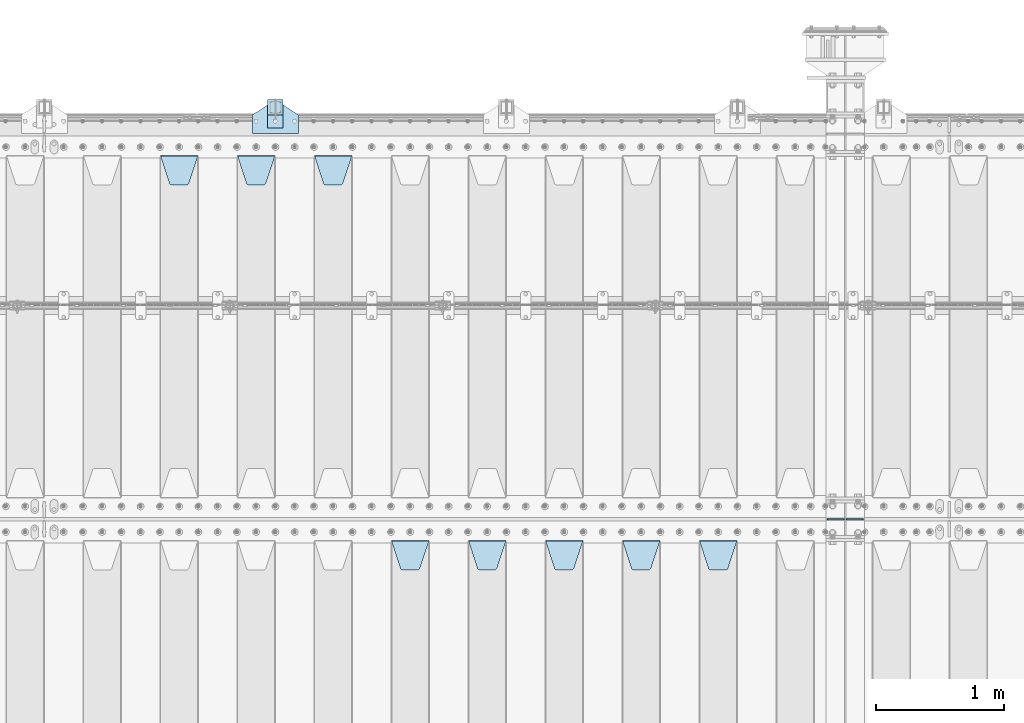
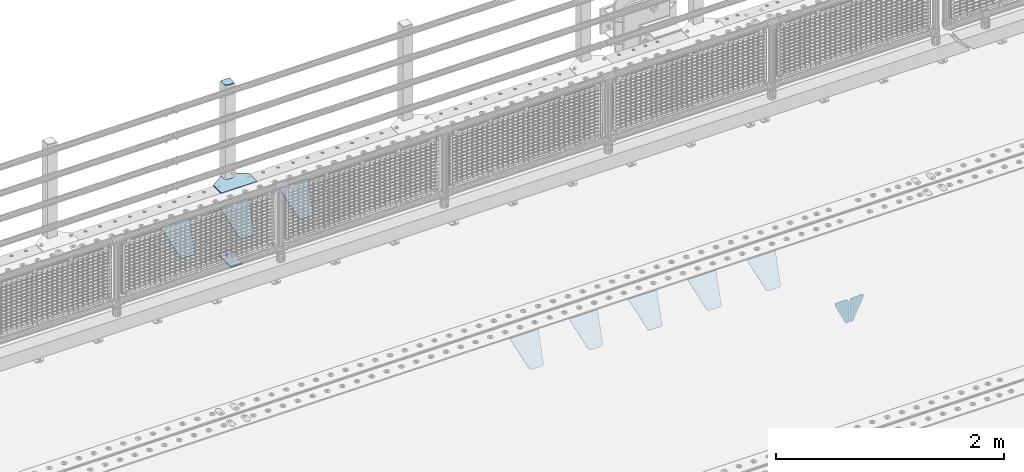
# One storey, part 216 of 240: 14 plates.
"""IFC2X3 building model written with IfcOpenShell, lengths in millimetres."""

from ifc_helpers import new_model, si_unit, frame, origin_with_axes, place, context, subcontext, project, spatial, faceted_brep, material, type_object, element, save


model = new_model("IFC2X3")

# Units and contexts
model_context = context("Model", 3, precision=1e-05, world=origin_with_axes())
body_context = subcontext(model_context, "Body", "Model", "MODEL_VIEW")
ifc_project = project(units=[si_unit("LENGTHUNIT", "METRE", prefix="MILLI"), si_unit("AREAUNIT", "SQUARE_METRE"), si_unit("VOLUMEUNIT", "CUBIC_METRE"), si_unit("MASSUNIT", "GRAM", prefix="KILO"), si_unit("TIMEUNIT", "SECOND"), si_unit("PLANEANGLEUNIT", "RADIAN"), si_unit("SOLIDANGLEUNIT", "STERADIAN"), si_unit("THERMODYNAMICTEMPERATUREUNIT", "DEGREE_CELSIUS"), si_unit("LUMINOUSINTENSITYUNIT", "LUMEN")], contexts=[model_context])

# Site, building, storey
site_placement = place(None, origin_with_axes())
site = spatial("IfcSite", under=ifc_project, at=site_placement, CompositionType="ELEMENT")
building_placement = place(site_placement, origin_with_axes())
building = spatial("IfcBuilding", under=site, at=building_placement, Name="Standard", CompositionType="ELEMENT")
storey_placement = place(building_placement, origin_with_axes())
storey = spatial("IfcBuildingStorey", under=building, at=storey_placement, Name="Undefined", CompositionType="ELEMENT", Elevation=0.0)

# Plates
ifc_material_1 = material(Name="STEEL/S355N")
plate_type_1 = type_object("IfcPlateType", PredefinedType="NOTDEFINED")
for number, where, z_axis, x_axis in (
    (1, (52833.499999997, 33000.0000000345, -915.000018222273), (0.0, 0.0, -1.0), (-1.0, 0.0, 0.0)),
    (2, (52846.4999999972, 33000.0000000345, -915.000018222272), (0.0, 0.0, -1.0), (1.0, 0.0, 0.0)),
):
    element("IfcPlate", number, at=place(storey_placement, frame(where, z_axis=z_axis, x_axis=x_axis)), inside=storey, type_object=plate_type_1, material=ifc_material_1, context=body_context, shape_type="Brep", body=[
        faceted_brep([(0.0, -5.0, 27.0), (0.0, -5.0, 250.0), (0.0, 5.0, 250.0), (0.0, 5.0, 27.0), (30.0, -5.0, 250.0), (30.0, 5.0, 250.0), (135.0, -5.0, 30.0), (135.0, 5.0, 30.0), (135.0, -5.0, 0.0), (135.0, 5.0, 0.0), (27.0, -5.0, 0.0), (27.0, 5.0, 0.0), (22.311499202995, -5.0, 0.410190668670339), (22.311499202995, 5.0, 0.410190668670339), (17.7654561302043, -5.0, 1.62829923878053), (17.7654561302043, 5.0, 1.62829923878053), (13.5, -5.0, 3.6173140978201), (13.5, 5.0, 3.6173140978201), (9.64473453846585, -5.0, 6.31680003578754), (9.64473453846585, 5.0, 6.31680003578754), (6.31680003579095, -5.0, 9.64473453846347), (6.31680003579095, 5.0, 9.64473453846347), (3.61731409782078, -5.0, 13.5), (3.61731409782078, 5.0, 13.5), (1.62829923877871, -5.0, 17.765456130207), (1.62829923877871, 5.0, 17.765456130207), (0.410190668670111, -5.0, 22.3114992029929), (0.410190668670111, 5.0, 22.3114992029929)], [[[0, 1, 2, 3]], [[1, 4, 5, 2]], [[4, 6, 7, 5]], [[6, 8, 9, 7]], [[8, 10, 11, 9]], [[10, 12, 13, 11]], [[12, 14, 15, 13]], [[14, 16, 17, 15]], [[16, 18, 19, 17]], [[18, 20, 21, 19]], [[20, 22, 23, 21]], [[22, 24, 25, 23]], [[24, 26, 27, 25]], [[26, 0, 3, 27]], [[5, 7, 9, 11, 13, 15, 17, 19, 21, 23, 25, 27, 3, 2]], [[26, 24, 22, 20, 18, 16, 14, 12, 10, 8, 6, 4, 1, 0]]]),
    ])
plate_type_2 = type_object("IfcPlateType", PredefinedType="NOTDEFINED")
plate_1_placement = place(storey_placement, frame((51705.0, 32831.767766956, -1.76776695296758), z_axis=(0.0, -0.707106781186547, -0.707106781186548), x_axis=(1.0, 0.0, 0.0)))
element("IfcPlate", 3, at=plate_1_placement, inside=storey, type_object=plate_type_2, material=ifc_material_1, context=body_context, shape_type="Brep", body=[
    faceted_brep([(0.0, -2.5, 0.0), (69.345504679477, -2.50000000000364, 300.171731424827), (69.345504679477, 2.49999999999636, 300.171731424827), (0.0, 2.5, 0.0), (70.927406119954, -2.50000000000364, 304.897442415397), (70.927406119954, 2.49999999999636, 304.897442415397), (73.3818627772271, -2.50000000000728, 309.234538108525), (73.3818627772271, 2.49999999999636, 309.234538108529), (76.6187032999587, -2.50000000000728, 313.023683126099), (76.6187032999587, 2.49999999999636, 313.023683126103), (80.5190132705029, -2.50000000000364, 316.125672595368), (80.5190132705029, 2.49999999999636, 316.125672595368), (84.9395038596849, -2.50000000000364, 318.426546230472), (84.9395038596849, 2.49999999999636, 318.426546230472), (89.7177759439219, -2.5, 319.841774983277), (89.7177759439219, 2.49999999999636, 319.841774983273), (94.6782862926484, -2.50000000000364, 320.319366455074), (94.6782862926484, 2.49999999999636, 320.319366455074), (195.321713707352, -2.50000000000364, 320.319366455074), (195.321713707352, 2.49999999999636, 320.319366455074), (200.282224056078, -2.50000000000364, 319.841774983273), (200.282224056078, 2.49999999999636, 319.841774983273), (205.060496140315, -2.50000000000364, 318.426546230472), (205.060496140315, 2.49999999999636, 318.426546230472), (209.480986729497, -2.50000000000364, 316.125672595368), (209.480986729497, 2.49999999999636, 316.125672595368), (213.381296700041, -2.50000000000728, 313.023683126099), (213.381296700041, 2.49999999999272, 313.023683126099), (216.618137222766, -2.50000000000364, 309.234538108522), (216.618137222766, 2.49999999999636, 309.234538108522), (219.072593880039, -2.50000000000364, 304.897442415397), (219.072593880039, 2.49999999999636, 304.897442415397), (220.654495320523, -2.50000000000364, 300.171731424827), (220.654495320523, 2.49999999999636, 300.171731424827), (290.0, -2.50000000000364, -3.63797880709171e-12), (290.0, 2.49999999999636, -3.63797880709171e-12)], [[[0, 1, 2, 3]], [[1, 4, 5, 2]], [[4, 6, 7, 5]], [[6, 8, 9, 7]], [[8, 10, 11, 9]], [[10, 12, 13, 11]], [[12, 14, 15, 13]], [[14, 16, 17, 15]], [[16, 18, 19, 17]], [[18, 20, 21, 19]], [[20, 22, 23, 21]], [[22, 24, 25, 23]], [[24, 26, 27, 25]], [[26, 28, 29, 27]], [[28, 30, 31, 29]], [[30, 32, 33, 31]], [[32, 34, 35, 33]], [[34, 0, 3, 35]], [[5, 7, 9, 11, 13, 15, 17, 19, 21, 23, 25, 27, 29, 31, 33, 35, 3, 2]], [[34, 32, 30, 28, 26, 24, 22, 20, 18, 16, 14, 12, 10, 8, 6, 4, 1, 0]]]),
])
plate_2_placement = place(storey_placement, frame((51105.0, 32831.767766956, -1.76776695296758), z_axis=(0.0, -0.707106781186547, -0.707106781186548), x_axis=(1.0, 0.0, 0.0)))
element("IfcPlate", 4, at=plate_2_placement, inside=storey, type_object=plate_type_2, material=ifc_material_1, context=body_context, shape_type="Brep", body=[
    faceted_brep([(0.0, -2.5, 0.0), (69.345504679477, -2.50000000000364, 300.171731424827), (69.345504679477, 2.49999999999636, 300.171731424827), (0.0, 2.5, 0.0), (70.927406119954, -2.50000000000364, 304.897442415397), (70.927406119954, 2.49999999999636, 304.897442415397), (73.3818627772271, -2.50000000000728, 309.234538108525), (73.3818627772271, 2.49999999999636, 309.234538108529), (76.6187032999587, -2.50000000000728, 313.023683126099), (76.6187032999587, 2.49999999999636, 313.023683126103), (80.5190132705029, -2.50000000000364, 316.125672595368), (80.5190132705029, 2.49999999999636, 316.125672595368), (84.9395038596849, -2.50000000000364, 318.426546230472), (84.9395038596849, 2.49999999999636, 318.426546230472), (89.7177759439219, -2.5, 319.841774983277), (89.7177759439219, 2.49999999999636, 319.841774983273), (94.6782862926484, -2.50000000000364, 320.319366455074), (94.6782862926484, 2.49999999999636, 320.319366455074), (195.321713707352, -2.50000000000364, 320.319366455074), (195.321713707352, 2.49999999999636, 320.319366455074), (200.282224056078, -2.50000000000364, 319.841774983273), (200.282224056078, 2.49999999999636, 319.841774983273), (205.060496140315, -2.50000000000364, 318.426546230472), (205.060496140315, 2.49999999999636, 318.426546230472), (209.480986729497, -2.50000000000364, 316.125672595368), (209.480986729497, 2.49999999999636, 316.125672595368), (213.381296700041, -2.50000000000728, 313.023683126099), (213.381296700041, 2.49999999999272, 313.023683126099), (216.618137222766, -2.50000000000364, 309.234538108522), (216.618137222766, 2.49999999999636, 309.234538108522), (219.072593880039, -2.50000000000364, 304.897442415397), (219.072593880039, 2.49999999999636, 304.897442415397), (220.654495320523, -2.50000000000364, 300.171731424827), (220.654495320523, 2.49999999999636, 300.171731424827), (290.0, -2.50000000000364, -3.63797880709171e-12), (290.0, 2.49999999999636, -3.63797880709171e-12)], [[[0, 1, 2, 3]], [[1, 4, 5, 2]], [[4, 6, 7, 5]], [[6, 8, 9, 7]], [[8, 10, 11, 9]], [[10, 12, 13, 11]], [[12, 14, 15, 13]], [[14, 16, 17, 15]], [[16, 18, 19, 17]], [[18, 20, 21, 19]], [[20, 22, 23, 21]], [[22, 24, 25, 23]], [[24, 26, 27, 25]], [[26, 28, 29, 27]], [[28, 30, 31, 29]], [[30, 32, 33, 31]], [[32, 34, 35, 33]], [[34, 0, 3, 35]], [[5, 7, 9, 11, 13, 15, 17, 19, 21, 23, 25, 27, 29, 31, 33, 35, 3, 2]], [[34, 32, 30, 28, 26, 24, 22, 20, 18, 16, 14, 12, 10, 8, 6, 4, 1, 0]]]),
])
plate_3_placement = place(storey_placement, frame((50505.0, 32831.767766956, -1.76776695296758), z_axis=(0.0, -0.707106781186547, -0.707106781186548), x_axis=(1.0, 0.0, 0.0)))
element("IfcPlate", 5, at=plate_3_placement, inside=storey, type_object=plate_type_2, material=ifc_material_1, context=body_context, shape_type="Brep", body=[
    faceted_brep([(0.0, -2.5, 0.0), (69.345504679477, -2.50000000000364, 300.171731424827), (69.345504679477, 2.49999999999636, 300.171731424827), (0.0, 2.5, 0.0), (70.927406119954, -2.50000000000364, 304.897442415397), (70.927406119954, 2.49999999999636, 304.897442415397), (73.3818627772271, -2.50000000000728, 309.234538108525), (73.3818627772271, 2.49999999999636, 309.234538108529), (76.6187032999587, -2.50000000000728, 313.023683126099), (76.6187032999587, 2.49999999999636, 313.023683126103), (80.5190132705029, -2.50000000000364, 316.125672595368), (80.5190132705029, 2.49999999999636, 316.125672595368), (84.9395038596849, -2.50000000000364, 318.426546230472), (84.9395038596849, 2.49999999999636, 318.426546230472), (89.7177759439219, -2.5, 319.841774983277), (89.7177759439219, 2.49999999999636, 319.841774983273), (94.6782862926484, -2.50000000000364, 320.319366455074), (94.6782862926484, 2.49999999999636, 320.319366455074), (195.321713707352, -2.50000000000364, 320.319366455074), (195.321713707352, 2.49999999999636, 320.319366455074), (200.282224056078, -2.50000000000364, 319.841774983273), (200.282224056078, 2.49999999999636, 319.841774983273), (205.060496140315, -2.50000000000364, 318.426546230472), (205.060496140315, 2.49999999999636, 318.426546230472), (209.480986729497, -2.50000000000364, 316.125672595368), (209.480986729497, 2.49999999999636, 316.125672595368), (213.381296700041, -2.50000000000728, 313.023683126099), (213.381296700041, 2.49999999999272, 313.023683126099), (216.618137222766, -2.50000000000364, 309.234538108522), (216.618137222766, 2.49999999999636, 309.234538108522), (219.072593880039, -2.50000000000364, 304.897442415397), (219.072593880039, 2.49999999999636, 304.897442415397), (220.654495320523, -2.50000000000364, 300.171731424827), (220.654495320523, 2.49999999999636, 300.171731424827), (290.0, -2.50000000000364, -3.63797880709171e-12), (290.0, 2.49999999999636, -3.63797880709171e-12)], [[[0, 1, 2, 3]], [[1, 4, 5, 2]], [[4, 6, 7, 5]], [[6, 8, 9, 7]], [[8, 10, 11, 9]], [[10, 12, 13, 11]], [[12, 14, 15, 13]], [[14, 16, 17, 15]], [[16, 18, 19, 17]], [[18, 20, 21, 19]], [[20, 22, 23, 21]], [[22, 24, 25, 23]], [[24, 26, 27, 25]], [[26, 28, 29, 27]], [[28, 30, 31, 29]], [[30, 32, 33, 31]], [[32, 34, 35, 33]], [[34, 0, 3, 35]], [[5, 7, 9, 11, 13, 15, 17, 19, 21, 23, 25, 27, 29, 31, 33, 35, 3, 2]], [[34, 32, 30, 28, 26, 24, 22, 20, 18, 16, 14, 12, 10, 8, 6, 4, 1, 0]]]),
])
plate_4_placement = place(storey_placement, frame((49905.0, 32831.767766956, -1.76776695296758), z_axis=(0.0, -0.707106781186547, -0.707106781186548), x_axis=(1.0, 0.0, 0.0)))
element("IfcPlate", 6, at=plate_4_placement, inside=storey, type_object=plate_type_2, material=ifc_material_1, context=body_context, shape_type="Brep", body=[
    faceted_brep([(0.0, -2.5, 0.0), (69.345504679477, -2.50000000000364, 300.171731424827), (69.345504679477, 2.49999999999636, 300.171731424827), (0.0, 2.5, 0.0), (70.927406119954, -2.50000000000364, 304.897442415397), (70.927406119954, 2.49999999999636, 304.897442415397), (73.3818627772271, -2.50000000000728, 309.234538108525), (73.3818627772271, 2.49999999999636, 309.234538108529), (76.6187032999587, -2.50000000000728, 313.023683126099), (76.6187032999587, 2.49999999999636, 313.023683126103), (80.5190132705029, -2.50000000000364, 316.125672595368), (80.5190132705029, 2.49999999999636, 316.125672595368), (84.9395038596849, -2.50000000000364, 318.426546230472), (84.9395038596849, 2.49999999999636, 318.426546230472), (89.7177759439219, -2.5, 319.841774983277), (89.7177759439219, 2.49999999999636, 319.841774983273), (94.6782862926484, -2.50000000000364, 320.319366455074), (94.6782862926484, 2.49999999999636, 320.319366455074), (195.321713707352, -2.50000000000364, 320.319366455074), (195.321713707352, 2.49999999999636, 320.319366455074), (200.282224056078, -2.50000000000364, 319.841774983273), (200.282224056078, 2.49999999999636, 319.841774983273), (205.060496140315, -2.50000000000364, 318.426546230472), (205.060496140315, 2.49999999999636, 318.426546230472), (209.480986729497, -2.50000000000364, 316.125672595368), (209.480986729497, 2.49999999999636, 316.125672595368), (213.381296700041, -2.50000000000728, 313.023683126099), (213.381296700041, 2.49999999999272, 313.023683126099), (216.618137222766, -2.50000000000364, 309.234538108522), (216.618137222766, 2.49999999999636, 309.234538108522), (219.072593880039, -2.50000000000364, 304.897442415397), (219.072593880039, 2.49999999999636, 304.897442415397), (220.654495320523, -2.50000000000364, 300.171731424827), (220.654495320523, 2.49999999999636, 300.171731424827), (290.0, -2.50000000000364, -3.63797880709171e-12), (290.0, 2.49999999999636, -3.63797880709171e-12)], [[[0, 1, 2, 3]], [[1, 4, 5, 2]], [[4, 6, 7, 5]], [[6, 8, 9, 7]], [[8, 10, 11, 9]], [[10, 12, 13, 11]], [[12, 14, 15, 13]], [[14, 16, 17, 15]], [[16, 18, 19, 17]], [[18, 20, 21, 19]], [[20, 22, 23, 21]], [[22, 24, 25, 23]], [[24, 26, 27, 25]], [[26, 28, 29, 27]], [[28, 30, 31, 29]], [[30, 32, 33, 31]], [[32, 34, 35, 33]], [[34, 0, 3, 35]], [[5, 7, 9, 11, 13, 15, 17, 19, 21, 23, 25, 27, 29, 31, 33, 35, 3, 2]], [[34, 32, 30, 28, 26, 24, 22, 20, 18, 16, 14, 12, 10, 8, 6, 4, 1, 0]]]),
])
plate_5_placement = place(storey_placement, frame((49305.0, 32831.767766956, -1.76776695296758), z_axis=(0.0, -0.707106781186547, -0.707106781186548), x_axis=(1.0, 0.0, 0.0)))
element("IfcPlate", 7, at=plate_5_placement, inside=storey, type_object=plate_type_2, material=ifc_material_1, context=body_context, shape_type="Brep", body=[
    faceted_brep([(0.0, -2.5, 0.0), (69.345504679477, -2.50000000000364, 300.171731424827), (69.345504679477, 2.49999999999636, 300.171731424827), (0.0, 2.5, 0.0), (70.927406119954, -2.50000000000364, 304.897442415397), (70.927406119954, 2.49999999999636, 304.897442415397), (73.3818627772271, -2.50000000000728, 309.234538108525), (73.3818627772271, 2.49999999999636, 309.234538108529), (76.6187032999587, -2.50000000000728, 313.023683126099), (76.6187032999587, 2.49999999999636, 313.023683126103), (80.5190132705029, -2.50000000000364, 316.125672595368), (80.5190132705029, 2.49999999999636, 316.125672595368), (84.9395038596849, -2.50000000000364, 318.426546230472), (84.9395038596849, 2.49999999999636, 318.426546230472), (89.7177759439219, -2.5, 319.841774983277), (89.7177759439219, 2.49999999999636, 319.841774983273), (94.6782862926484, -2.50000000000364, 320.319366455074), (94.6782862926484, 2.49999999999636, 320.319366455074), (195.321713707352, -2.50000000000364, 320.319366455074), (195.321713707352, 2.49999999999636, 320.319366455074), (200.282224056078, -2.50000000000364, 319.841774983273), (200.282224056078, 2.49999999999636, 319.841774983273), (205.060496140315, -2.50000000000364, 318.426546230472), (205.060496140315, 2.49999999999636, 318.426546230472), (209.480986729497, -2.50000000000364, 316.125672595368), (209.480986729497, 2.49999999999636, 316.125672595368), (213.381296700041, -2.50000000000728, 313.023683126099), (213.381296700041, 2.49999999999272, 313.023683126099), (216.618137222766, -2.50000000000364, 309.234538108522), (216.618137222766, 2.49999999999636, 309.234538108522), (219.072593880039, -2.50000000000364, 304.897442415397), (219.072593880039, 2.49999999999636, 304.897442415397), (220.654495320523, -2.50000000000364, 300.171731424827), (220.654495320523, 2.49999999999636, 300.171731424827), (290.0, -2.50000000000364, -3.63797880709171e-12), (290.0, 2.49999999999636, -3.63797880709171e-12)], [[[0, 1, 2, 3]], [[1, 4, 5, 2]], [[4, 6, 7, 5]], [[6, 8, 9, 7]], [[8, 10, 11, 9]], [[10, 12, 13, 11]], [[12, 14, 15, 13]], [[14, 16, 17, 15]], [[16, 18, 19, 17]], [[18, 20, 21, 19]], [[20, 22, 23, 21]], [[22, 24, 25, 23]], [[24, 26, 27, 25]], [[26, 28, 29, 27]], [[28, 30, 31, 29]], [[30, 32, 33, 31]], [[32, 34, 35, 33]], [[34, 0, 3, 35]], [[5, 7, 9, 11, 13, 15, 17, 19, 21, 23, 25, 27, 29, 31, 33, 35, 3, 2]], [[34, 32, 30, 28, 26, 24, 22, 20, 18, 16, 14, 12, 10, 8, 6, 4, 1, 0]]]),
])
plate_6_placement = place(storey_placement, frame((48705.0, 35831.767766956, -1.76776695296758), z_axis=(0.0, -0.707106781186547, -0.707106781186548), x_axis=(1.0, 0.0, 0.0)))
element("IfcPlate", 8, at=plate_6_placement, inside=storey, type_object=plate_type_2, material=ifc_material_1, context=body_context, shape_type="Brep", body=[
    faceted_brep([(0.0, -2.5, 0.0), (69.345504679477, -2.50000000000364, 300.171731424827), (69.345504679477, 2.49999999999636, 300.171731424827), (0.0, 2.5, 0.0), (70.927406119954, -2.50000000000364, 304.897442415397), (70.927406119954, 2.49999999999636, 304.897442415397), (73.3818627772271, -2.50000000000728, 309.234538108525), (73.3818627772271, 2.49999999999636, 309.234538108529), (76.6187032999587, -2.50000000000728, 313.023683126099), (76.6187032999587, 2.49999999999636, 313.023683126103), (80.5190132705029, -2.50000000000364, 316.125672595368), (80.5190132705029, 2.49999999999636, 316.125672595368), (84.9395038596849, -2.50000000000364, 318.426546230472), (84.9395038596849, 2.49999999999636, 318.426546230472), (89.7177759439219, -2.5, 319.841774983277), (89.7177759439219, 2.49999999999636, 319.841774983273), (94.6782862926484, -2.50000000000364, 320.319366455074), (94.6782862926484, 2.49999999999636, 320.319366455074), (195.321713707352, -2.50000000000364, 320.319366455074), (195.321713707352, 2.49999999999636, 320.319366455074), (200.282224056078, -2.50000000000364, 319.841774983273), (200.282224056078, 2.49999999999636, 319.841774983273), (205.060496140315, -2.50000000000364, 318.426546230472), (205.060496140315, 2.49999999999636, 318.426546230472), (209.480986729497, -2.50000000000364, 316.125672595368), (209.480986729497, 2.49999999999636, 316.125672595368), (213.381296700041, -2.50000000000728, 313.023683126099), (213.381296700041, 2.49999999999272, 313.023683126099), (216.618137222766, -2.50000000000364, 309.234538108522), (216.618137222766, 2.49999999999636, 309.234538108522), (219.072593880039, -2.50000000000364, 304.897442415397), (219.072593880039, 2.49999999999636, 304.897442415397), (220.654495320523, -2.50000000000364, 300.171731424827), (220.654495320523, 2.49999999999636, 300.171731424827), (290.0, -2.50000000000364, -3.63797880709171e-12), (290.0, 2.49999999999636, -3.63797880709171e-12)], [[[0, 1, 2, 3]], [[1, 4, 5, 2]], [[4, 6, 7, 5]], [[6, 8, 9, 7]], [[8, 10, 11, 9]], [[10, 12, 13, 11]], [[12, 14, 15, 13]], [[14, 16, 17, 15]], [[16, 18, 19, 17]], [[18, 20, 21, 19]], [[20, 22, 23, 21]], [[22, 24, 25, 23]], [[24, 26, 27, 25]], [[26, 28, 29, 27]], [[28, 30, 31, 29]], [[30, 32, 33, 31]], [[32, 34, 35, 33]], [[34, 0, 3, 35]], [[5, 7, 9, 11, 13, 15, 17, 19, 21, 23, 25, 27, 29, 31, 33, 35, 3, 2]], [[34, 32, 30, 28, 26, 24, 22, 20, 18, 16, 14, 12, 10, 8, 6, 4, 1, 0]]]),
])
plate_7_placement = place(storey_placement, frame((48105.0, 35831.767766956, -1.76776695296758), z_axis=(0.0, -0.707106781186547, -0.707106781186548), x_axis=(1.0, 0.0, 0.0)))
element("IfcPlate", 9, at=plate_7_placement, inside=storey, type_object=plate_type_2, material=ifc_material_1, context=body_context, shape_type="Brep", body=[
    faceted_brep([(0.0, -2.5, 0.0), (69.345504679477, -2.50000000000364, 300.171731424827), (69.345504679477, 2.49999999999636, 300.171731424827), (0.0, 2.5, 0.0), (70.927406119954, -2.50000000000364, 304.897442415397), (70.927406119954, 2.49999999999636, 304.897442415397), (73.3818627772271, -2.50000000000728, 309.234538108525), (73.3818627772271, 2.49999999999636, 309.234538108529), (76.6187032999587, -2.50000000000728, 313.023683126099), (76.6187032999587, 2.49999999999636, 313.023683126103), (80.5190132705029, -2.50000000000364, 316.125672595368), (80.5190132705029, 2.49999999999636, 316.125672595368), (84.9395038596849, -2.50000000000364, 318.426546230472), (84.9395038596849, 2.49999999999636, 318.426546230472), (89.7177759439219, -2.5, 319.841774983277), (89.7177759439219, 2.49999999999636, 319.841774983273), (94.6782862926484, -2.50000000000364, 320.319366455074), (94.6782862926484, 2.49999999999636, 320.319366455074), (195.321713707352, -2.50000000000364, 320.319366455074), (195.321713707352, 2.49999999999636, 320.319366455074), (200.282224056078, -2.50000000000364, 319.841774983273), (200.282224056078, 2.49999999999636, 319.841774983273), (205.060496140315, -2.50000000000364, 318.426546230472), (205.060496140315, 2.49999999999636, 318.426546230472), (209.480986729497, -2.50000000000364, 316.125672595368), (209.480986729497, 2.49999999999636, 316.125672595368), (213.381296700041, -2.50000000000728, 313.023683126099), (213.381296700041, 2.49999999999272, 313.023683126099), (216.618137222766, -2.50000000000364, 309.234538108522), (216.618137222766, 2.49999999999636, 309.234538108522), (219.072593880039, -2.50000000000364, 304.897442415397), (219.072593880039, 2.49999999999636, 304.897442415397), (220.654495320523, -2.50000000000364, 300.171731424827), (220.654495320523, 2.49999999999636, 300.171731424827), (290.0, -2.50000000000364, -3.63797880709171e-12), (290.0, 2.49999999999636, -3.63797880709171e-12)], [[[0, 1, 2, 3]], [[1, 4, 5, 2]], [[4, 6, 7, 5]], [[6, 8, 9, 7]], [[8, 10, 11, 9]], [[10, 12, 13, 11]], [[12, 14, 15, 13]], [[14, 16, 17, 15]], [[16, 18, 19, 17]], [[18, 20, 21, 19]], [[20, 22, 23, 21]], [[22, 24, 25, 23]], [[24, 26, 27, 25]], [[26, 28, 29, 27]], [[28, 30, 31, 29]], [[30, 32, 33, 31]], [[32, 34, 35, 33]], [[34, 0, 3, 35]], [[5, 7, 9, 11, 13, 15, 17, 19, 21, 23, 25, 27, 29, 31, 33, 35, 3, 2]], [[34, 32, 30, 28, 26, 24, 22, 20, 18, 16, 14, 12, 10, 8, 6, 4, 1, 0]]]),
])
plate_8_placement = place(storey_placement, frame((47505.0, 35831.767766956, -1.76776695296758), z_axis=(0.0, -0.707106781186547, -0.707106781186548), x_axis=(1.0, 0.0, 0.0)))
element("IfcPlate", 10, at=plate_8_placement, inside=storey, type_object=plate_type_2, material=ifc_material_1, context=body_context, shape_type="Brep", body=[
    faceted_brep([(0.0, -2.5, 0.0), (69.345504679477, -2.50000000000364, 300.171731424827), (69.345504679477, 2.49999999999636, 300.171731424827), (0.0, 2.5, 0.0), (70.927406119954, -2.50000000000364, 304.897442415397), (70.927406119954, 2.49999999999636, 304.897442415397), (73.3818627772271, -2.50000000000728, 309.234538108525), (73.3818627772271, 2.49999999999636, 309.234538108529), (76.6187032999587, -2.50000000000728, 313.023683126099), (76.6187032999587, 2.49999999999636, 313.023683126103), (80.5190132705029, -2.50000000000364, 316.125672595368), (80.5190132705029, 2.49999999999636, 316.125672595368), (84.9395038596849, -2.50000000000364, 318.426546230472), (84.9395038596849, 2.49999999999636, 318.426546230472), (89.7177759439219, -2.5, 319.841774983277), (89.7177759439219, 2.49999999999636, 319.841774983273), (94.6782862926484, -2.50000000000364, 320.319366455074), (94.6782862926484, 2.49999999999636, 320.319366455074), (195.321713707352, -2.50000000000364, 320.319366455074), (195.321713707352, 2.49999999999636, 320.319366455074), (200.282224056078, -2.50000000000364, 319.841774983273), (200.282224056078, 2.49999999999636, 319.841774983273), (205.060496140315, -2.50000000000364, 318.426546230472), (205.060496140315, 2.49999999999636, 318.426546230472), (209.480986729497, -2.50000000000364, 316.125672595368), (209.480986729497, 2.49999999999636, 316.125672595368), (213.381296700041, -2.50000000000728, 313.023683126099), (213.381296700041, 2.49999999999272, 313.023683126099), (216.618137222766, -2.50000000000364, 309.234538108522), (216.618137222766, 2.49999999999636, 309.234538108522), (219.072593880039, -2.50000000000364, 304.897442415397), (219.072593880039, 2.49999999999636, 304.897442415397), (220.654495320523, -2.50000000000364, 300.171731424827), (220.654495320523, 2.49999999999636, 300.171731424827), (290.0, -2.50000000000364, -3.63797880709171e-12), (290.0, 2.49999999999636, -3.63797880709171e-12)], [[[0, 1, 2, 3]], [[1, 4, 5, 2]], [[4, 6, 7, 5]], [[6, 8, 9, 7]], [[8, 10, 11, 9]], [[10, 12, 13, 11]], [[12, 14, 15, 13]], [[14, 16, 17, 15]], [[16, 18, 19, 17]], [[18, 20, 21, 19]], [[20, 22, 23, 21]], [[22, 24, 25, 23]], [[24, 26, 27, 25]], [[26, 28, 29, 27]], [[28, 30, 31, 29]], [[30, 32, 33, 31]], [[32, 34, 35, 33]], [[34, 0, 3, 35]], [[5, 7, 9, 11, 13, 15, 17, 19, 21, 23, 25, 27, 29, 31, 33, 35, 3, 2]], [[34, 32, 30, 28, 26, 24, 22, 20, 18, 16, 14, 12, 10, 8, 6, 4, 1, 0]]]),
])
ifc_material_2 = material(Name="STEEL/S355J2")
plate_type_3 = type_object("IfcPlateType", PredefinedType="NOTDEFINED")
plate_9_placement = place(storey_placement, frame((48220.0, 36005.0, 5.00000000004911), z_axis=(0.0, 1.0, 0.0), x_axis=(1.0, 0.0, 0.0)))
element("IfcPlate", 11, at=plate_9_placement, inside=storey, type_object=plate_type_3, material=ifc_material_2, context=body_context, shape_type="Brep", body=[
    faceted_brep([(0.0, -5.0, 0.0), (2.31396552408114e-06, -5.0, 145.0), (2.31396552408114e-06, 5.0, 145.0), (0.0, 5.0, 0.0), (130.0, -5.0, 230.0), (130.0, 5.0, 230.0), (130.0, -5.0, 180.0), (130.0, 5.0, 180.0), (130.48036798992, -5.0, 175.122741949599), (130.48036798992, 5.0, 175.122741949599), (131.903011687216, -5.0, 170.432914190875), (131.903011687216, 5.0, 170.432914190875), (134.213259692435, -5.0, 166.110744174512), (134.213259692435, 5.0, 166.110744174512), (137.322330470335, -5.0, 162.322330470335), (137.322330470335, 5.0, 162.322330470335), (141.110744174512, -5.0, 159.213259692435), (141.110744174512, 5.0, 159.213259692435), (145.432914190875, -5.0, 156.903011687216), (145.432914190875, 5.0, 156.903011687216), (150.122741949599, -5.0, 155.48036798992), (150.122741949599, 5.0, 155.48036798992), (155.0, -5.0, 155.0), (155.0, 5.0, 155.0), (205.0, -5.0, 155.0), (205.0, 5.0, 155.0), (209.877258050401, -5.0, 155.48036798992), (209.877258050401, 5.0, 155.48036798992), (214.567085809125, -5.0, 156.903011687216), (214.567085809125, 5.0, 156.903011687216), (218.889255825488, -5.0, 159.213259692435), (218.889255825488, 5.0, 159.213259692435), (222.677669529665, -5.0, 162.322330470335), (222.677669529665, 5.0, 162.322330470335), (225.786740307565, -5.0, 166.110744174512), (225.786740307565, 5.0, 166.110744174512), (228.096988312784, -5.0, 170.432914190875), (228.096988312784, 5.0, 170.432914190875), (229.51963201008, -5.0, 175.122741949599), (229.51963201008, 5.0, 175.122741949599), (230.0, -5.0, 180.0), (230.0, 5.0, 180.0), (230.0, -5.0, 230.0), (230.0, 5.0, 230.0), (360.0, -5.0, 145.0), (360.0, 5.0, 145.0), (360.0, -5.0, -7.27595761418343e-12), (360.0, 5.0, -7.27595761418343e-12)], [[[0, 1, 2, 3]], [[1, 4, 5, 2]], [[4, 6, 7, 5]], [[6, 8, 9, 7]], [[8, 10, 11, 9]], [[10, 12, 13, 11]], [[12, 14, 15, 13]], [[14, 16, 17, 15]], [[16, 18, 19, 17]], [[18, 20, 21, 19]], [[20, 22, 23, 21]], [[22, 24, 25, 23]], [[24, 26, 27, 25]], [[26, 28, 29, 27]], [[28, 30, 31, 29]], [[30, 32, 33, 31]], [[32, 34, 35, 33]], [[34, 36, 37, 35]], [[36, 38, 39, 37]], [[38, 40, 41, 39]], [[40, 42, 43, 41]], [[42, 44, 45, 43]], [[44, 46, 47, 45]], [[46, 0, 3, 47]], [[5, 7, 9, 11, 13, 15, 17, 19, 21, 23, 25, 27, 29, 31, 33, 35, 37, 39, 41, 43, 45, 47, 3, 2]], [[46, 44, 42, 40, 38, 36, 34, 32, 30, 28, 26, 24, 22, 20, 18, 16, 14, 12, 10, 8, 6, 4, 1, 0]]]),
])
plate_type_4 = type_object("IfcPlateType", PredefinedType="NOTDEFINED")
plate_10_placement = place(storey_placement, frame((48340.0000000001, 36050.0000000002, -850.000000000002), z_axis=(0.0, 1.0, 0.0), x_axis=(1.0, 0.0, 0.0)))
element("IfcPlate", 12, at=plate_10_placement, inside=storey, type_object=plate_type_4, material=ifc_material_2, context=body_context, shape_type="Brep", body=[
    faceted_brep([(66.3639610305399, -5.0, 163.636038969111), (66.3639610305399, 5.0, 163.636038969111), (59.9999999998618, 5.0, 160.999999999789), (59.9999999998618, -5.0, 160.999999999789), (53.6360389691836, 5.0, 163.636038969111), (53.6360389691836, -5.0, 163.636038969111), (50.9999999998618, 5.0, 169.999999999789), (50.9999999998618, -5.0, 169.999999999789), (53.6360389691836, 5.0, 176.363961030467), (53.6360389691836, -5.0, 176.363961030467), (59.9999999998618, 5.0, 178.999999999789), (59.9999999998618, -5.0, 178.999999999789), (66.3639610305399, 5.0, 176.363961030467), (66.3639610305399, -5.0, 176.363961030467), (68.9999999998618, 5.0, 169.999999999789), (68.9999999998618, -5.0, 169.999999999789), (120.0, -5.0, 0.0), (120.0, -5.0, 220.0), (0.0, -5.0, 220.0), (0.0, -5.0, 0.0), (0.0, 5.0, 0.0), (120.0, 5.0, 0.0), (120.0, 5.0, 220.0), (0.0, 5.0, 220.0)], [[[0, 1, 2, 3]], [[3, 2, 4, 5]], [[5, 4, 6, 7]], [[7, 6, 8, 9]], [[9, 8, 10, 11]], [[11, 10, 12, 13]], [[13, 12, 14, 15]], [[15, 14, 1, 0]], [[16, 17, 18, 19], [3, 5, 7, 9, 11, 13, 15, 0]], [[16, 19, 20, 21]], [[17, 16, 21, 22]], [[18, 17, 22, 23]], [[19, 18, 23, 20]], [[22, 21, 20, 23], [10, 8, 6, 4, 2, 1, 14, 12]]]),
])
plate_type_5 = type_object("IfcPlateType", PredefinedType="NOTDEFINED")
plate_11_placement = place(storey_placement, frame((48444.0000000001, 36166.0000000002, 1012.50000000001), z_axis=(0.0, 1.0, 0.0), x_axis=(-1.0, 0.0, 0.0)))
element("IfcPlate", 13, at=plate_11_placement, inside=storey, type_object=plate_type_5, material=ifc_material_2, context=body_context, shape_type="Brep", body=[
    faceted_brep([(0.0, -2.5, 19.0), (0.0, -2.5, 69.0), (0.0, 2.5, 69.0), (0.0, 2.5, 19.0), (0.476369668547704, -2.5, 73.2278977451715), (0.476369668547704, 2.5, 73.2278977451715), (1.88159150985302, -2.5, 77.2437910432345), (1.88159150985302, 2.5, 77.2437910432345), (4.14520183311106, -2.5, 80.8463062353185), (4.14520183311106, 2.5, 80.8463062353185), (7.15369376468152, -2.5, 83.8547981668889), (7.15369376468152, 2.5, 83.8547981668889), (10.7562089567655, -2.5, 86.118408490147), (10.7562089567655, 2.5, 86.118408490147), (14.7721022548285, -2.5, 87.5236303314523), (14.7721022548285, 2.5, 87.5236303314523), (19.0, -2.5, 88.0), (19.0, 2.5, 88.0), (69.0, -2.5, 88.0), (69.0, 2.5, 88.0), (73.2278977451715, -2.5, 87.5236303314523), (73.2278977451715, 2.5, 87.5236303314523), (77.2437910432345, -2.5, 86.118408490147), (77.2437910432345, 2.5, 86.118408490147), (80.8463062353185, -2.5, 83.8547981668889), (80.8463062353185, 2.5, 83.8547981668889), (83.8547981668889, -2.5, 80.8463062353185), (83.8547981668889, 2.5, 80.8463062353185), (86.118408490147, -2.5, 77.2437910432345), (86.118408490147, 2.5, 77.2437910432345), (87.5236303314523, -2.5, 73.2278977451715), (87.5236303314523, 2.5, 73.2278977451715), (88.0, -2.5, 69.0), (88.0, 2.5, 69.0), (88.0, -2.5, 19.0), (88.0, 2.5, 19.0), (87.5236303314523, -2.5, 14.7721022548285), (87.5236303314523, 2.5, 14.7721022548285), (86.118408490147, -2.5, 10.7562089567655), (86.118408490147, 2.5, 10.7562089567655), (83.8547981668889, -2.5, 7.15369376468152), (83.8547981668889, 2.5, 7.15369376468152), (80.8463062353185, -2.5, 4.14520183311106), (80.8463062353185, 2.5, 4.14520183311106), (77.2437910432345, -2.5, 1.88159150985302), (77.2437910432345, 2.5, 1.88159150985302), (73.2278977451715, -2.5, 0.476369668547704), (73.2278977451715, 2.5, 0.476369668547704), (69.0, -2.5, 0.0), (69.0, 2.5, 0.0), (19.0, -2.5, 0.0), (19.0, 2.5, 0.0), (14.7721022548285, -2.5, 0.476369668547704), (14.7721022548285, 2.5, 0.476369668547704), (10.7562089567655, -2.5, 1.88159150985302), (10.7562089567655, 2.5, 1.88159150985302), (7.15369376468152, -2.5, 4.14520183311106), (7.15369376468152, 2.5, 4.14520183311106), (4.14520183311106, -2.5, 7.15369376468152), (4.14520183311106, 2.5, 7.15369376468152), (1.88159150985302, -2.5, 10.7562089567655), (1.88159150985302, 2.5, 10.7562089567655), (0.476369668547704, -2.5, 14.7721022548285), (0.476369668547704, 2.5, 14.7721022548285)], [[[0, 1, 2, 3]], [[1, 4, 5, 2]], [[4, 6, 7, 5]], [[6, 8, 9, 7]], [[8, 10, 11, 9]], [[10, 12, 13, 11]], [[12, 14, 15, 13]], [[14, 16, 17, 15]], [[16, 18, 19, 17]], [[18, 20, 21, 19]], [[20, 22, 23, 21]], [[22, 24, 25, 23]], [[24, 26, 27, 25]], [[26, 28, 29, 27]], [[28, 30, 31, 29]], [[30, 32, 33, 31]], [[32, 34, 35, 33]], [[34, 36, 37, 35]], [[36, 38, 39, 37]], [[38, 40, 41, 39]], [[40, 42, 43, 41]], [[42, 44, 45, 43]], [[44, 46, 47, 45]], [[46, 48, 49, 47]], [[48, 50, 51, 49]], [[50, 52, 53, 51]], [[52, 54, 55, 53]], [[54, 56, 57, 55]], [[56, 58, 59, 57]], [[58, 60, 61, 59]], [[60, 62, 63, 61]], [[62, 0, 3, 63]], [[5, 7, 9, 11, 13, 15, 17, 19, 21, 23, 25, 27, 29, 31, 33, 35, 37, 39, 41, 43, 45, 47, 49, 51, 53, 55, 57, 59, 61, 63, 3, 2]], [[62, 60, 58, 56, 54, 52, 50, 48, 46, 44, 42, 40, 38, 36, 34, 32, 30, 28, 26, 24, 22, 20, 18, 16, 14, 12, 10, 8, 6, 4, 1, 0]]]),
])
plate_type_6 = type_object("IfcPlateType", PredefinedType="NOTDEFINED")
plate_12_placement = place(storey_placement, frame((48340.0000000001, 36050.0000000002, -857.500000000002), z_axis=(0.0, 1.0, 0.0), x_axis=(1.0, 0.0, 0.0)))
element("IfcPlate", 14, at=plate_12_placement, inside=storey, type_object=plate_type_6, material=ifc_material_2, context=body_context, shape_type="Brep", body=[
    faceted_brep([(0.0, -2.5, 0.0), (0.0, -2.5, 100.0), (0.0, 2.5, 100.0), (0.0, 2.5, 0.0), (120.0, -2.5, 100.0), (120.0, 2.5, 100.0), (120.0, -2.5, 0.0), (120.0, 2.5, 0.0)], [[[0, 1, 2, 3]], [[1, 4, 5, 2]], [[4, 6, 7, 5]], [[6, 0, 3, 7]], [[5, 7, 3, 2]], [[6, 4, 1, 0]]]),
])

save(model, "model.ifc")
